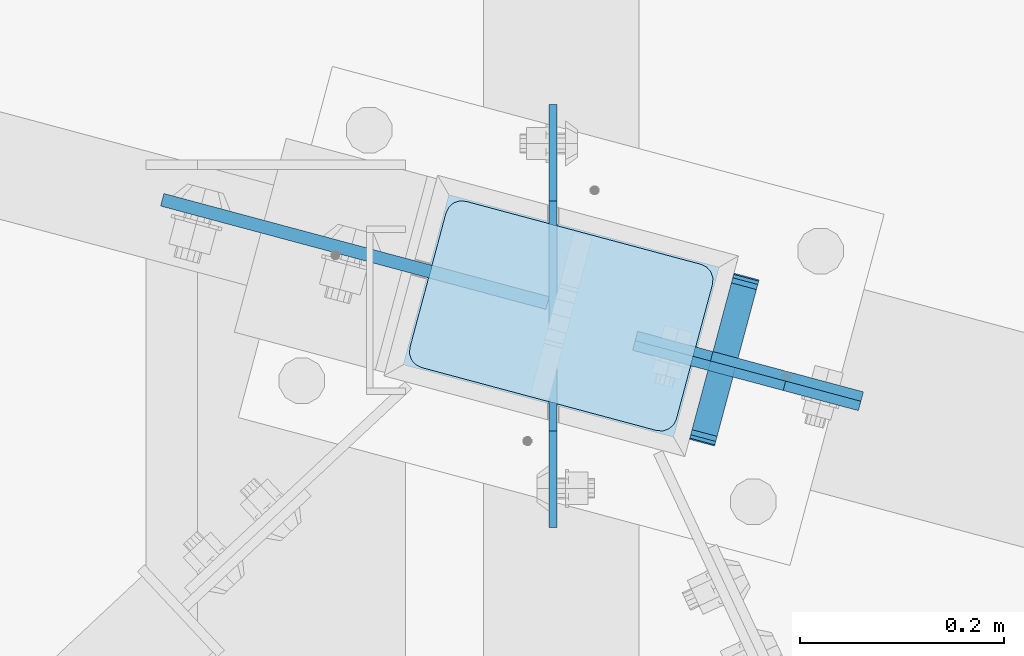
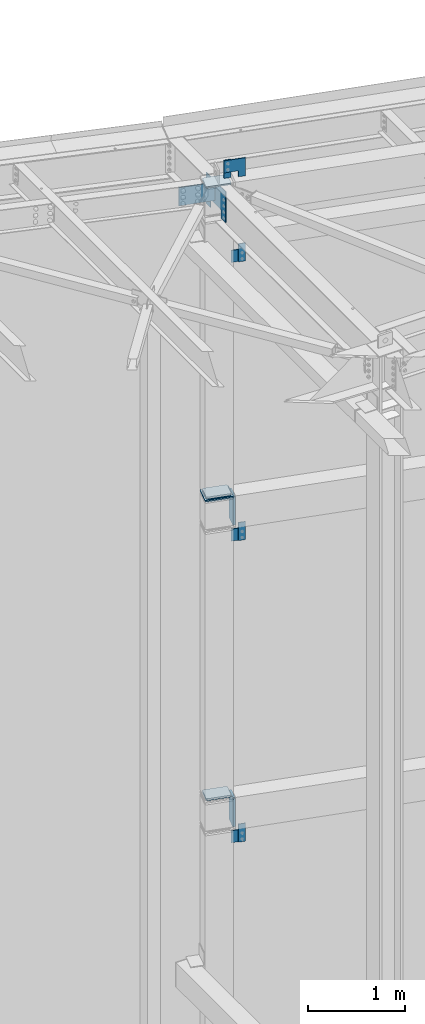
# One storey, part 1664 of 1763: 17 plates, 5 elements without a shape of their own.
"""IFC2X3 building model written with IfcOpenShell, lengths in millimetres."""

from ifc_helpers import new_model, si_unit, frame, origin_with_axes, place, context, subcontext, project, spatial, faceted_brep, material, type_object, element, aggregate, save


model = new_model("IFC2X3")

# Units and contexts
model_context = context("Model", 3, precision=1e-05, world=origin_with_axes())
body_context = subcontext(model_context, "Body", "Model", "MODEL_VIEW")
ifc_project = project(units=[si_unit("LENGTHUNIT", "METRE", prefix="MILLI"), si_unit("AREAUNIT", "SQUARE_METRE"), si_unit("VOLUMEUNIT", "CUBIC_METRE"), si_unit("MASSUNIT", "GRAM", prefix="KILO"), si_unit("TIMEUNIT", "SECOND"), si_unit("PLANEANGLEUNIT", "RADIAN"), si_unit("SOLIDANGLEUNIT", "STERADIAN"), si_unit("THERMODYNAMICTEMPERATUREUNIT", "DEGREE_CELSIUS"), si_unit("LUMINOUSINTENSITYUNIT", "LUMEN")], contexts=[model_context])

# Site, building, storey
site_placement = place(None, origin_with_axes())
site = spatial("IfcSite", under=ifc_project, at=site_placement, CompositionType="ELEMENT")
building_placement = place(site_placement, origin_with_axes())
building = spatial("IfcBuilding", under=site, at=building_placement, Name="Undefined", CompositionType="ELEMENT")
storey_placement = place(building_placement, origin_with_axes())
storey = spatial("IfcBuildingStorey", under=building, at=storey_placement, Name="Undefined", CompositionType="ELEMENT", Elevation=0.0)

# Assembly, plate
assembly_1_placement = place(storey_placement, origin_with_axes())
assembly_1 = element("IfcElementAssembly", 1, at=assembly_1_placement, inside=storey, Name="BEAM", AssemblyPlace="NOTDEFINED", PredefinedType="RIGID_FRAME")
ifc_material_1 = material(Name="STEEL/A36")
plate_type_1 = type_object("IfcPlateType", PredefinedType="NOTDEFINED")
plate_1_placement = place(assembly_1_placement, frame((-39453.9346929631, 66613.0335251458, 4267.19999084485), z_axis=(0.0, 0.0, -1.0), x_axis=(0.965925826295336, -0.25881904507913, 0.0)))
plate_1 = element("IfcPlate", 2, at=plate_1_placement, type_object=plate_type_1, material=ifc_material_1, Name="PLATE", context=body_context, shape_type="Brep", body=[
    faceted_brep([(0.0, -4.76249999999982, 0.0), (-2.83762346953154e-10, -4.7624999996915, 228.600006103516), (-2.83762346953154e-10, 4.76250000028813, 228.600006103517), (0.0, 4.76249999999982, 0.0), (76.1999969480166, -4.76249999961874, 228.600006103516), (76.1999969480166, 4.76250000036089, 228.600006103517), (76.1999969482931, -4.76249999991705, 0.0), (76.1999969482931, 4.76250000006257, 1.81898940354586e-12)], [[[0, 1, 2, 3]], [[1, 4, 5, 2]], [[4, 6, 7, 5]], [[6, 0, 3, 7]], [[5, 7, 3, 2]], [[6, 4, 1, 0]]]),
])

assembly_2_placement = place(storey_placement, origin_with_axes())
assembly_2 = element("IfcElementAssembly", 3, at=assembly_2_placement, inside=storey, Name="COLUMN", AssemblyPlace="NOTDEFINED", PredefinedType="RIGID_FRAME")
plate_2_placement = place(assembly_2_placement, frame((-39598.6758127814, 66661.6778126115, 12445.9953409909), z_axis=(-3.1917423766572e-06, 8.53930963785388e-07, 0.999999999994542), x_axis=(0.96592582365611, -0.258819054907767, 3.30399998729133e-06)))
plate_2 = element("IfcPlate", 4, at=plate_2_placement, type_object=plate_type_1, material=ifc_material_1, Name="PLATE", context=body_context, shape_type="Brep", body=[
    faceted_brep([(0.0, -4.76249999999982, 0.0), (-2.83762346953154e-10, -4.7624999996915, 228.600006103516), (-2.83762346953154e-10, 4.76250000028813, 228.600006103517), (0.0, 4.76249999999982, 0.0), (76.1999969480166, -4.76249999961874, 228.600006103516), (76.1999969480166, 4.76250000036089, 228.600006103517), (76.1999969482931, -4.76249999991705, 0.0), (76.1999969482931, 4.76250000006257, 1.81898940354586e-12)], [[[0, 1, 2, 3]], [[1, 4, 5, 2]], [[4, 6, 7, 5]], [[6, 0, 3, 7]], [[5, 7, 3, 2]], [[6, 4, 1, 0]]]),
])

assembly_3_placement = place(storey_placement, origin_with_axes())
assembly_3 = element("IfcElementAssembly", 5, at=assembly_3_placement, inside=storey, Name="BEAM", AssemblyPlace="NOTDEFINED", PredefinedType="RIGID_FRAME")
plate_3_placement = place(assembly_3_placement, frame((-39453.9346929706, 66613.0335251479, 8077.19999084485), z_axis=(0.0, 0.0, -1.0), x_axis=(0.965925826295336, -0.25881904507913, 0.0)))
plate_3 = element("IfcPlate", 6, at=plate_3_placement, type_object=plate_type_1, material=ifc_material_1, Name="PLATE", context=body_context, shape_type="Brep", body=[
    faceted_brep([(0.0, -4.76249999999982, 0.0), (-2.83762346953154e-10, -4.7624999996915, 228.600006103516), (-2.83762346953154e-10, 4.76250000028813, 228.600006103517), (0.0, 4.76249999999982, 0.0), (76.1999969480166, -4.76249999961874, 228.600006103516), (76.1999969480166, 4.76250000036089, 228.600006103517), (76.1999969482931, -4.76249999991705, 0.0), (76.1999969482931, 4.76250000006257, 1.81898940354586e-12)], [[[0, 1, 2, 3]], [[1, 4, 5, 2]], [[4, 6, 7, 5]], [[6, 0, 3, 7]], [[5, 7, 3, 2]], [[6, 4, 1, 0]]]),
])

assembly_4_placement = place(storey_placement, origin_with_axes())
assembly_4 = element("IfcElementAssembly", 7, at=assembly_4_placement, inside=storey, Name="BEAM", AssemblyPlace="NOTDEFINED", PredefinedType="RIGID_FRAME")
plate_4_placement = place(assembly_4_placement, frame((-39453.9346899535, 66613.0335364077, 11598.2749908449), z_axis=(0.0, 0.0, -1.0), x_axis=(0.965925826295336, -0.25881904507913, 0.0)))
plate_4 = element("IfcPlate", 8, at=plate_4_placement, type_object=plate_type_1, material=ifc_material_1, Name="PLATE", context=body_context, shape_type="Brep", body=[
    faceted_brep([(0.0, -4.76249999999982, 0.0), (-2.83762346953154e-10, -4.7624999996915, 228.600006103516), (-2.83762346953154e-10, 4.76250000028813, 228.600006103517), (0.0, 4.76249999999982, 0.0), (76.1999969480166, -4.76249999961874, 228.600006103516), (76.1999969480166, 4.76250000036089, 228.600006103517), (76.1999969482931, -4.76249999991705, 0.0), (76.1999969482931, 4.76250000006257, 1.81898940354586e-12)], [[[0, 1, 2, 3]], [[1, 4, 5, 2]], [[4, 6, 7, 5]], [[6, 0, 3, 7]], [[5, 7, 3, 2]], [[6, 4, 1, 0]]]),
])
aggregate(assembly_4, [plate_4])

# Plate
plate_type_2 = type_object("IfcPlateType", PredefinedType="NOTDEFINED")
plate_5_placement = place(assembly_1_placement, frame((-39491.0419311829, 66719.9497266416, 4284.92161424868), z_axis=(-1.25579324012506e-05, -4.68677477038e-05, 0.999999998822856), x_axis=(-0.258819045024454, -0.965925825091317, -4.85210000061005e-05)))
plate_5 = element("IfcPlate", 9, at=plate_5_placement, type_object=plate_type_2, material=ifc_material_1, Name="PLATE", context=body_context, shape_type="Brep", body=[
    faceted_brep([(-0.000210669619264081, -12.6999999999534, 15.8747893276304), (-0.0047190601399052, -12.6999999998734, 355.599795431186), (-0.00471906022721669, 12.7000000000335, 355.599795431181), (-0.000210669699299615, 12.6999999999462, 15.874789327625), (1.2036328949398, -12.6999999998734, 361.674959615151), (1.20363289484521, 12.7000000000189, 361.674959615146), (4.64488630341657, -12.6999999998734, 366.825251770753), (4.64488630330743, 12.7000000000189, 366.825251770748), (9.79513279069943, -12.6999999998807, 370.266573526937), (9.79513279059029, 12.7000000000116, 370.266573526933), (15.870280938434, -12.6999999998952, 371.47500610361), (15.8702809383467, 12.7000000000044, 371.475006103608), (152.395291187866, -12.7000000001281, 371.475006103574), (152.395291187757, 12.6999999997643, 371.475006103572), (158.470342028959, -12.7000000001353, 370.266613832635), (158.47034202885, 12.699999999757, 370.266613832629), (163.620536872309, -12.7000000001644, 366.825400721296), (163.620536872222, 12.6999999997352, 366.825400721291), (167.061818314192, -12.7000000001644, 361.675251535087), (167.06181831409, 12.6999999997279, 361.675251535082), (168.270291186484, -12.7000000001644, 355.600216727018), (168.270291186389, 12.6999999997279, 355.600216727014), (168.274798528968, -12.7000000002445, 15.8752106238717), (168.274798528873, 12.6999999996478, 15.8752106238662), (167.066446559853, -12.7000000002445, 9.80004645495683), (167.066446559766, 12.6999999996551, 9.80004645495319), (163.625193148131, -12.7000000002372, 4.64975431598214), (163.625193148022, 12.6999999996478, 4.64975431597668), (158.474946666858, -12.7000000002372, 1.2084325724245), (158.474946666771, 12.6999999996624, 1.20843257241904), (152.399798530452, -12.7000000002226, 4.20186552219093e-10), (152.399798530358, 12.6999999996697, 4.14729584008455e-10), (15.8747893290638, -12.6999999999898, 4.72937244921923e-11), (15.8747893289692, 12.6999999999098, 4.36557456851006e-11), (9.79973849928501, -12.699999999968, 1.20839226628777), (9.79973849918315, 12.6999999999243, 1.20839226628414), (4.64954366190068, -12.699999999968, 4.6496053649953), (4.64954366179882, 12.6999999999316, 4.64960536499166), (1.20826221675816, -12.6999999999607, 9.79975453459156), (1.20826221665629, 12.6999999999462, 9.79975453458792)], [[[0, 1, 2, 3]], [[1, 4, 5, 2]], [[4, 6, 7, 5]], [[6, 8, 9, 7]], [[8, 10, 11, 9]], [[10, 12, 13, 11]], [[12, 14, 15, 13]], [[14, 16, 17, 15]], [[16, 18, 19, 17]], [[18, 20, 21, 19]], [[20, 22, 23, 21]], [[22, 24, 25, 23]], [[24, 26, 27, 25]], [[26, 28, 29, 27]], [[28, 30, 31, 29]], [[30, 32, 33, 31]], [[32, 34, 35, 33]], [[34, 36, 37, 35]], [[36, 38, 39, 37]], [[38, 0, 3, 39]], [[5, 7, 9, 11, 13, 15, 17, 19, 21, 23, 25, 27, 29, 31, 33, 35, 37, 39, 3, 2]], [[38, 36, 34, 32, 30, 28, 26, 24, 22, 20, 18, 16, 14, 12, 10, 8, 6, 4, 1, 0]]]),
])

aggregate(assembly_1, [plate_5, plate_1])

plate_6_placement = place(assembly_3_placement, frame((-39491.0419311902, 66719.9497266432, 8094.92161424868), z_axis=(-1.25579324012506e-05, -4.68677477038e-05, 0.999999998822856), x_axis=(-0.258819045024454, -0.965925825091317, -4.85210000061005e-05)))
plate_6 = element("IfcPlate", 10, at=plate_6_placement, type_object=plate_type_2, material=ifc_material_1, Name="PLATE", context=body_context, shape_type="Brep", body=[
    faceted_brep([(-0.000210669619264081, -12.6999999999534, 15.8747893276304), (-0.0047190601399052, -12.6999999998734, 355.599795431186), (-0.00471906022721669, 12.7000000000335, 355.599795431181), (-0.000210669699299615, 12.6999999999462, 15.874789327625), (1.2036328949398, -12.6999999998734, 361.674959615151), (1.20363289484521, 12.7000000000189, 361.674959615146), (4.64488630341657, -12.6999999998734, 366.825251770753), (4.64488630330743, 12.7000000000189, 366.825251770748), (9.79513279069943, -12.6999999998807, 370.266573526937), (9.79513279059029, 12.7000000000116, 370.266573526933), (15.870280938434, -12.6999999998952, 371.47500610361), (15.8702809383467, 12.7000000000044, 371.475006103608), (152.395291187866, -12.7000000001281, 371.475006103574), (152.395291187757, 12.6999999997643, 371.475006103572), (158.470342028959, -12.7000000001353, 370.266613832635), (158.47034202885, 12.699999999757, 370.266613832629), (163.620536872309, -12.7000000001644, 366.825400721296), (163.620536872222, 12.6999999997352, 366.825400721291), (167.061818314192, -12.7000000001644, 361.675251535087), (167.06181831409, 12.6999999997279, 361.675251535082), (168.270291186484, -12.7000000001644, 355.600216727018), (168.270291186389, 12.6999999997279, 355.600216727014), (168.274798528968, -12.7000000002445, 15.8752106238717), (168.274798528873, 12.6999999996478, 15.8752106238662), (167.066446559853, -12.7000000002445, 9.80004645495683), (167.066446559766, 12.6999999996551, 9.80004645495319), (163.625193148131, -12.7000000002372, 4.64975431598214), (163.625193148022, 12.6999999996478, 4.64975431597668), (158.474946666858, -12.7000000002372, 1.2084325724245), (158.474946666771, 12.6999999996624, 1.20843257241904), (152.399798530452, -12.7000000002226, 4.20186552219093e-10), (152.399798530358, 12.6999999996697, 4.14729584008455e-10), (15.8747893290638, -12.6999999999898, 4.72937244921923e-11), (15.8747893289692, 12.6999999999098, 4.36557456851006e-11), (9.79973849928501, -12.699999999968, 1.20839226628777), (9.79973849918315, 12.6999999999243, 1.20839226628414), (4.64954366190068, -12.699999999968, 4.6496053649953), (4.64954366179882, 12.6999999999316, 4.64960536499166), (1.20826221675816, -12.6999999999607, 9.79975453459156), (1.20826221665629, 12.6999999999462, 9.79975453458792)], [[[0, 1, 2, 3]], [[1, 4, 5, 2]], [[4, 6, 7, 5]], [[6, 8, 9, 7]], [[8, 10, 11, 9]], [[10, 12, 13, 11]], [[12, 14, 15, 13]], [[14, 16, 17, 15]], [[16, 18, 19, 17]], [[18, 20, 21, 19]], [[20, 22, 23, 21]], [[22, 24, 25, 23]], [[24, 26, 27, 25]], [[26, 28, 29, 27]], [[28, 30, 31, 29]], [[30, 32, 33, 31]], [[32, 34, 35, 33]], [[34, 36, 37, 35]], [[36, 38, 39, 37]], [[38, 0, 3, 39]], [[5, 7, 9, 11, 13, 15, 17, 19, 21, 23, 25, 27, 29, 31, 33, 35, 37, 39, 3, 2]], [[38, 36, 34, 32, 30, 28, 26, 24, 22, 20, 18, 16, 14, 12, 10, 8, 6, 4, 1, 0]]]),
])

aggregate(assembly_3, [plate_6, plate_3])

plate_7_placement = place(assembly_2_placement, frame((-39780.8472022481, 66797.6028150253, 4686.3), z_axis=(0.965913267114843, -0.258865912030785, 0.0), x_axis=(-0.258865912030778, -0.965913267114844, 3.00823476209188e-08)))
plate_7 = element("IfcPlate", 11, at=plate_7_placement, type_object=plate_type_2, material=ifc_material_1, Name="PLATE", context=body_context, shape_type="Brep", body=[
    faceted_brep([(-2.18278728425503e-11, -12.7000000000007, 15.875), (-1.67347025126219e-10, -12.7000000000007, 253.999999999985), (-1.67347025126219e-10, 12.7000000000007, 253.999999999985), (-2.18278728425503e-11, 12.7000000000007, 15.875), (1.20841242121242, -12.7000000000007, 260.075099488779), (1.20841242121242, 12.7000000000007, 260.075099488779), (4.649679848495, -12.7000000000007, 265.225320151323), (4.649679848495, 12.7000000000007, 265.225320151323), (9.79990051103232, -12.7000000000007, 268.666587578606), (9.79990051103232, 12.7000000000007, 268.666587578606), (15.8749999998181, -12.7000000000007, 269.874999999993), (15.8749999998181, 12.7000000000007, 269.874999999993), (152.400009155084, -12.7000000000007, 269.875000000073), (152.400009155084, 12.7000000000007, 269.875000000073), (158.475108643877, -12.7000000000007, 268.6665875787), (158.475108643877, 12.7000000000007, 268.6665875787), (163.625329306422, -12.7000000000007, 265.225320151425), (163.625329306422, 12.7000000000007, 265.225320151425), (167.066596733705, -12.7000000000007, 260.07509948888), (167.066596733705, 12.7000000000007, 260.07509948888), (168.275009155092, -12.7000000000007, 254.000000000087), (168.275009155092, 12.7000000000007, 254.000000000087), (168.275009155237, -12.7000000000007, 15.8750000001019), (168.275009155237, 12.7000000000007, 15.8750000001019), (167.066596733865, -12.7000000000007, 9.79990051130881), (167.066596733865, 12.7000000000007, 9.79990051130881), (163.625329306582, -12.7000000000007, 4.64967984876421), (163.625329306582, 12.7000000000007, 4.64967984876421), (158.475108644045, -12.7000000000007, 1.20841242148163), (158.475108644045, 12.7000000000007, 1.20841242148163), (152.400000000001, -12.6999998092651, 0.0), (152.400000000001, 12.6999998092651, 0.0), (15.8749999999854, -12.7000000000007, 0.0), (15.8749999999854, 12.7000000000007, 0.0), (9.79990051119239, -12.7000000000007, 1.20841242137976), (9.79990051119239, 12.7000000000007, 1.20841242137976), (4.64967984864779, -12.7000000000007, 4.64967984866234), (4.64967984864779, 12.7000000000007, 4.64967984866234), (1.20841242136521, -12.7000000000007, 9.79990051119967), (1.20841242136521, 12.7000000000007, 9.79990051119967)], [[[0, 1, 2, 3]], [[1, 4, 5, 2]], [[4, 6, 7, 5]], [[6, 8, 9, 7]], [[8, 10, 11, 9]], [[10, 12, 13, 11]], [[12, 14, 15, 13]], [[14, 16, 17, 15]], [[16, 18, 19, 17]], [[18, 20, 21, 19]], [[20, 22, 23, 21]], [[22, 24, 25, 23]], [[24, 26, 27, 25]], [[26, 28, 29, 27]], [[28, 30, 31, 29]], [[30, 32, 33, 31]], [[32, 34, 35, 33]], [[34, 36, 37, 35]], [[36, 38, 39, 37]], [[38, 0, 3, 39]], [[5, 7, 9, 11, 13, 15, 17, 19, 21, 23, 25, 27, 29, 31, 33, 35, 37, 39, 3, 2]], [[38, 36, 34, 32, 30, 28, 26, 24, 22, 20, 18, 16, 14, 12, 10, 8, 6, 4, 1, 0]]]),
])

plate_8_placement = place(assembly_2_placement, frame((-39780.8472021543, 66797.6028150001, 8496.3), z_axis=(0.965913267114843, -0.258865912030785, 0.0), x_axis=(-0.258865912030778, -0.965913267114844, 3.00823476209188e-08)))
plate_8 = element("IfcPlate", 12, at=plate_8_placement, type_object=plate_type_2, material=ifc_material_1, Name="PLATE", context=body_context, shape_type="Brep", body=[
    faceted_brep([(-2.18278728425503e-11, -12.7000000000007, 15.875), (-1.67347025126219e-10, -12.7000000000007, 253.999999999985), (-1.67347025126219e-10, 12.7000000000007, 253.999999999985), (-2.18278728425503e-11, 12.7000000000007, 15.875), (1.20841242121242, -12.7000000000007, 260.075099488779), (1.20841242121242, 12.7000000000007, 260.075099488779), (4.649679848495, -12.7000000000007, 265.225320151323), (4.649679848495, 12.7000000000007, 265.225320151323), (9.79990051103232, -12.7000000000007, 268.666587578606), (9.79990051103232, 12.7000000000007, 268.666587578606), (15.8749999998181, -12.7000000000007, 269.874999999993), (15.8749999998181, 12.7000000000007, 269.874999999993), (152.400009155084, -12.7000000000007, 269.875000000073), (152.400009155084, 12.7000000000007, 269.875000000073), (158.475108643877, -12.7000000000007, 268.6665875787), (158.475108643877, 12.7000000000007, 268.6665875787), (163.625329306422, -12.7000000000007, 265.225320151425), (163.625329306422, 12.7000000000007, 265.225320151425), (167.066596733705, -12.7000000000007, 260.07509948888), (167.066596733705, 12.7000000000007, 260.07509948888), (168.275009155092, -12.7000000000007, 254.000000000087), (168.275009155092, 12.7000000000007, 254.000000000087), (168.275009155237, -12.7000000000007, 15.8750000001019), (168.275009155237, 12.7000000000007, 15.8750000001019), (167.066596733865, -12.7000000000007, 9.79990051130881), (167.066596733865, 12.7000000000007, 9.79990051130881), (163.625329306582, -12.7000000000007, 4.64967984876421), (163.625329306582, 12.7000000000007, 4.64967984876421), (158.475108644045, -12.7000000000007, 1.20841242148163), (158.475108644045, 12.7000000000007, 1.20841242148163), (152.400000000001, -12.6999998092651, 0.0), (152.400000000001, 12.6999998092651, 0.0), (15.8749999999854, -12.7000000000007, 0.0), (15.8749999999854, 12.7000000000007, 0.0), (9.79990051119239, -12.7000000000007, 1.20841242137976), (9.79990051119239, 12.7000000000007, 1.20841242137976), (4.64967984864779, -12.7000000000007, 4.64967984866234), (4.64967984864779, 12.7000000000007, 4.64967984866234), (1.20841242136521, -12.7000000000007, 9.79990051119967), (1.20841242136521, 12.7000000000007, 9.79990051119967)], [[[0, 1, 2, 3]], [[1, 4, 5, 2]], [[4, 6, 7, 5]], [[6, 8, 9, 7]], [[8, 10, 11, 9]], [[10, 12, 13, 11]], [[12, 14, 15, 13]], [[14, 16, 17, 15]], [[16, 18, 19, 17]], [[18, 20, 21, 19]], [[20, 22, 23, 21]], [[22, 24, 25, 23]], [[24, 26, 27, 25]], [[26, 28, 29, 27]], [[28, 30, 31, 29]], [[30, 32, 33, 31]], [[32, 34, 35, 33]], [[34, 36, 37, 35]], [[36, 38, 39, 37]], [[38, 0, 3, 39]], [[5, 7, 9, 11, 13, 15, 17, 19, 21, 23, 25, 27, 29, 31, 33, 35, 37, 39, 3, 2]], [[38, 36, 34, 32, 30, 28, 26, 24, 22, 20, 18, 16, 14, 12, 10, 8, 6, 4, 1, 0]]]),
])

plate_9_placement = place(assembly_2_placement, frame((-39780.8472021916, 66797.6028150101, 8455.025), z_axis=(0.965913267114843, -0.258865912030785, 0.0), x_axis=(-0.258865912030778, -0.965913267114844, 3.00823476209188e-08)))
plate_9 = element("IfcPlate", 13, at=plate_9_placement, type_object=plate_type_2, material=ifc_material_1, Name="PLATE", context=body_context, shape_type="Brep", body=[
    faceted_brep([(-2.18278728425503e-11, -12.7000000000007, 15.875), (-1.67347025126219e-10, -12.7000000000007, 253.999999999985), (-1.67347025126219e-10, 12.7000000000007, 253.999999999985), (-2.18278728425503e-11, 12.7000000000007, 15.875), (1.20841242121242, -12.7000000000007, 260.075099488779), (1.20841242121242, 12.7000000000007, 260.075099488779), (4.649679848495, -12.7000000000007, 265.225320151323), (4.649679848495, 12.7000000000007, 265.225320151323), (9.79990051103232, -12.7000000000007, 268.666587578606), (9.79990051103232, 12.7000000000007, 268.666587578606), (15.8749999998181, -12.7000000000007, 269.874999999993), (15.8749999998181, 12.7000000000007, 269.874999999993), (152.400009155084, -12.7000000000007, 269.875000000073), (152.400009155084, 12.7000000000007, 269.875000000073), (158.475108643877, -12.7000000000007, 268.6665875787), (158.475108643877, 12.7000000000007, 268.6665875787), (163.625329306422, -12.7000000000007, 265.225320151425), (163.625329306422, 12.7000000000007, 265.225320151425), (167.066596733705, -12.7000000000007, 260.07509948888), (167.066596733705, 12.7000000000007, 260.07509948888), (168.275009155092, -12.7000000000007, 254.000000000087), (168.275009155092, 12.7000000000007, 254.000000000087), (168.275009155237, -12.7000000000007, 15.8750000001019), (168.275009155237, 12.7000000000007, 15.8750000001019), (167.066596733865, -12.7000000000007, 9.79990051130881), (167.066596733865, 12.7000000000007, 9.79990051130881), (163.625329306582, -12.7000000000007, 4.64967984876421), (163.625329306582, 12.7000000000007, 4.64967984876421), (158.475108644045, -12.7000000000007, 1.20841242148163), (158.475108644045, 12.7000000000007, 1.20841242148163), (152.400000000001, -12.6999998092651, 0.0), (152.400000000001, 12.6999998092651, 0.0), (15.8749999999854, -12.7000000000007, 0.0), (15.8749999999854, 12.7000000000007, 0.0), (9.79990051119239, -12.7000000000007, 1.20841242137976), (9.79990051119239, 12.7000000000007, 1.20841242137976), (4.64967984864779, -12.7000000000007, 4.64967984866234), (4.64967984864779, 12.7000000000007, 4.64967984866234), (1.20841242136521, -12.7000000000007, 9.79990051119967), (1.20841242136521, 12.7000000000007, 9.79990051119967)], [[[0, 1, 2, 3]], [[1, 4, 5, 2]], [[4, 6, 7, 5]], [[6, 8, 9, 7]], [[8, 10, 11, 9]], [[10, 12, 13, 11]], [[12, 14, 15, 13]], [[14, 16, 17, 15]], [[16, 18, 19, 17]], [[18, 20, 21, 19]], [[20, 22, 23, 21]], [[22, 24, 25, 23]], [[24, 26, 27, 25]], [[26, 28, 29, 27]], [[28, 30, 31, 29]], [[30, 32, 33, 31]], [[32, 34, 35, 33]], [[34, 36, 37, 35]], [[36, 38, 39, 37]], [[38, 0, 3, 39]], [[5, 7, 9, 11, 13, 15, 17, 19, 21, 23, 25, 27, 29, 31, 33, 35, 37, 39, 3, 2]], [[38, 36, 34, 32, 30, 28, 26, 24, 22, 20, 18, 16, 14, 12, 10, 8, 6, 4, 1, 0]]]),
])

# Assembly, plate
assembly_5_placement = place(storey_placement, origin_with_axes())
assembly_5 = element("IfcElementAssembly", 14, at=assembly_5_placement, inside=storey, Name="BEAM", AssemblyPlace="NOTDEFINED", PredefinedType="RIGID_FRAME")
plate_type_3 = type_object("IfcPlateType", PredefinedType="NOTDEFINED")
plate_10_placement = place(assembly_5_placement, frame((-39380.3240270479, 66593.3096185596, 12674.5518666303), z_axis=(-9.02279432266368e-05, 2.41809847939294e-05, -0.999999995637099), x_axis=(-0.965925818045195, 0.258819059012118, 9.34120000055757e-05)))
plate_10 = element("IfcPlate", 15, at=plate_10_placement, type_object=plate_type_3, material=ifc_material_1, Name="PLATE", context=body_context, shape_type="Brep", body=[
    faceted_brep([(0.0, -4.76249999999982, 0.0), (-0.0147415312894736, -4.76250000055734, 228.577880859459), (-0.0147415312967496, 4.76249999946594, 228.577880859457), (0.0, 4.76249999999982, 0.0), (76.1926269535688, -4.76250000031723, 228.563140869262), (76.1926269535616, 4.76249999970605, 228.563140869261), (76.1999969485987, -4.76250000013533, 152.385253906345), (76.1999969485914, 4.76249999988795, 152.385253906343), (228.59263610909, -4.76249999964057, 152.399993896655), (228.592636109082, 4.76250000037544, 152.399993896655), (228.607376099128, -4.76249999928405, 2.14640749618411e-10), (228.607376099135, 4.76250000073924, 2.12821760214865e-10)], [[[0, 1, 2, 3]], [[1, 4, 5, 2]], [[4, 6, 7, 5]], [[6, 8, 9, 7]], [[8, 10, 11, 9]], [[10, 0, 3, 11]], [[5, 7, 9, 11, 3, 2]], [[10, 8, 6, 4, 1, 0]]]),
])
aggregate(assembly_5, [plate_10])

# Plate
plate_type_4 = type_object("IfcPlateType", PredefinedType="NOTDEFINED")
plate_11_placement = place(assembly_2_placement, frame((-39780.8472031505, 66797.6028121075, 12420.6), z_axis=(0.965913267114843, -0.258865912030785, 0.0), x_axis=(-0.258865912030778, -0.965913267114844, 3.00823476209188e-08)))
plate_11 = element("IfcPlate", 16, at=plate_11_placement, type_object=plate_type_4, material=ifc_material_1, Name="PLATE", context=body_context, shape_type="Brep", body=[
    faceted_brep([(7.27595761418343e-11, -9.52499999999964, 15.8750000001601), (1.13504938781261e-09, -9.52499999999964, 254.000000000065), (1.13504938781261e-09, 9.52499999999964, 254.000000000065), (7.27595761418343e-11, 9.52499999999964, 15.8750000001601), (1.20841242253664, -9.52499999999964, 260.075099488837), (1.20841242253664, 9.52499999999964, 260.075099488837), (4.64967984981922, -9.52499999999964, 265.225320151352), (4.64967984981922, 9.52499999999964, 265.225320151352), (9.79990051234927, -9.52499999999964, 268.666587578613), (9.79990051234927, 9.52499999999964, 268.666587578613), (15.8750000011278, -9.52499999999964, 269.874999999993), (15.8750000011278, 9.52499999999964, 269.874999999993), (152.400009155099, -9.52499999999964, 269.87500000008), (152.400009155099, 9.52499999999964, 269.87500000008), (158.475108643885, -9.52499999999964, 268.6665875787), (158.475108643885, 9.52499999999964, 268.6665875787), (163.625329306429, -9.52499999999964, 265.225320151425), (163.625329306429, 9.52499999999964, 265.225320151425), (167.066596733726, -9.52499999999964, 260.07509948888), (167.066596733726, 9.52499999999964, 260.07509948888), (168.275009155106, -9.52499999999964, 254.000000000087), (168.275009155106, 9.52499999999964, 254.000000000087), (168.275009155259, -9.52499999999964, 15.8750000008658), (168.275009155259, 9.52499999999964, 15.8750000008658), (167.066596733886, -9.52499999999964, 9.79990051209461), (167.066596733886, 9.52499999999964, 9.79990051209461), (163.625329306633, -9.52499999999964, 4.64967984955729), (163.625329306633, 9.52499999999964, 4.64967984955729), (158.475108644117, -9.52499999999964, 1.20841242226743), (158.475108644117, 9.52499999999964, 1.20841242226743), (152.400009155353, -9.52499999999964, 8.58562998473644e-10), (152.400009155353, 9.52499999999964, 8.58562998473644e-10), (15.8750000001673, -9.52499999999964, 8.73114913702011e-11), (15.8750000001673, 9.52499999999964, 8.73114913702011e-11), (9.79990051132336, -9.52499999999964, 1.20841242144525), (9.79990051132336, 9.52499999999964, 1.20841242144525), (4.64967984874238, -9.52499999999964, 4.64967984874238), (4.64967984874238, 9.52499999999964, 4.64967984874238), (1.20841242144525, -9.52499999999964, 9.79990051132336), (1.20841242144525, 9.52499999999964, 9.79990051132336)], [[[0, 1, 2, 3]], [[1, 4, 5, 2]], [[4, 6, 7, 5]], [[6, 8, 9, 7]], [[8, 10, 11, 9]], [[10, 12, 13, 11]], [[12, 14, 15, 13]], [[14, 16, 17, 15]], [[16, 18, 19, 17]], [[18, 20, 21, 19]], [[20, 22, 23, 21]], [[22, 24, 25, 23]], [[24, 26, 27, 25]], [[26, 28, 29, 27]], [[28, 30, 31, 29]], [[30, 32, 33, 31]], [[32, 34, 35, 33]], [[34, 36, 37, 35]], [[36, 38, 39, 37]], [[38, 0, 3, 39]], [[5, 7, 9, 11, 13, 15, 17, 19, 21, 23, 25, 27, 29, 31, 33, 35, 37, 39, 3, 2]], [[38, 36, 34, 32, 30, 28, 26, 24, 22, 20, 18, 16, 14, 12, 10, 8, 6, 4, 1, 0]]]),
])

ifc_material_2 = material(Name="STEEL/A572-50")
plate_type_5 = type_object("IfcPlateType", PredefinedType="NOTDEFINED")
plate_12_placement = place(assembly_2_placement, frame((-39793.1844873819, 66818.987968072, 8475.6625), z_axis=(0.965913267114843, -0.258865912030785, 0.0), x_axis=(-0.258865912030778, -0.965913267114844, 3.00823476209188e-08)))
plate_12 = element("IfcPlate", 17, at=plate_12_placement, type_object=plate_type_5, material=ifc_material_2, Name="PLATE", context=body_context, shape_type="Brep", body=[
    faceted_brep([(-7.27595761418343e-12, -7.9375, 0.0), (-1.96450855582952e-10, -7.9375, 304.799987792954), (-1.96450855582952e-10, 7.9375, 304.799987792954), (-7.27595761418343e-12, 7.9375, 0.0), (203.199996948031, -7.9375, 304.799987793078), (203.199996948031, 7.9375, 304.799987793078), (203.199996948228, -7.9375, 1.30967237055302e-10), (203.199996948228, 7.9375, 1.30967237055302e-10)], [[[0, 1, 2, 3]], [[1, 4, 5, 2]], [[4, 6, 7, 5]], [[6, 0, 3, 7]], [[5, 7, 3, 2]], [[6, 4, 1, 0]]]),
])

plate_type_6 = type_object("IfcPlateType", PredefinedType="NOTDEFINED")
plate_13_placement = place(assembly_2_placement, frame((-39377.8658925294, 66602.5119729023, 4038.59998474133), z_axis=(0.0, 0.0, 1.0), x_axis=(-0.965925827679309, 0.258819039914073, 0.0)))
plate_13 = element("IfcPlate", 18, at=plate_13_placement, type_object=plate_type_6, material=ifc_material_1, Name="PLATE", context=body_context, shape_type="Brep", body=[
    faceted_brep([(0.0, -4.76249999999982, 0.0), (-3.05175672110636e-06, -4.7625000002663, 152.399993896484), (-3.05175490211695e-06, 4.76249999972788, 152.399993896484), (0.0, 4.76249999999982, 0.0), (152.400009155272, -4.76249999975698, 152.399993896484), (152.400009155273, 4.76250000024447, 152.399993896484), (152.400009155272, -4.76249999948777, 5.45696821063757e-12), (152.400009155273, 4.76250000051368, 3.63797880709171e-12)], [[[0, 1, 2, 3]], [[1, 4, 5, 2]], [[4, 6, 7, 5]], [[6, 0, 3, 7]], [[5, 7, 3, 2]], [[6, 4, 1, 0]]]),
])

plate_14_placement = place(assembly_2_placement, frame((-39377.8658925294, 66602.5119729022, 7848.59998474133), z_axis=(0.0, 0.0, 1.0), x_axis=(-0.965925827679309, 0.258819039914073, 0.0)))
plate_14 = element("IfcPlate", 19, at=plate_14_placement, type_object=plate_type_6, material=ifc_material_1, Name="PLATE", context=body_context, shape_type="Brep", body=[
    faceted_brep([(0.0, -4.76249999999982, 0.0), (-3.05175672110636e-06, -4.7625000002663, 152.399993896484), (-3.05175490211695e-06, 4.76249999972788, 152.399993896484), (0.0, 4.76249999999982, 0.0), (152.400009155272, -4.76249999975698, 152.399993896484), (152.400009155273, 4.76250000024447, 152.399993896484), (152.400009155272, -4.76249999948777, 5.45696821063757e-12), (152.400009155273, 4.76250000051368, 3.63797880709171e-12)], [[[0, 1, 2, 3]], [[1, 4, 5, 2]], [[4, 6, 7, 5]], [[6, 0, 3, 7]], [[5, 7, 3, 2]], [[6, 4, 1, 0]]]),
])

plate_15_placement = place(assembly_2_placement, frame((-39377.8658925295, 66602.5119729022, 11369.6749847413), z_axis=(0.0, 0.0, 1.0), x_axis=(-0.965925827679309, 0.258819039914073, 0.0)))
plate_15 = element("IfcPlate", 20, at=plate_15_placement, type_object=plate_type_6, material=ifc_material_1, Name="PLATE", context=body_context, shape_type="Brep", body=[
    faceted_brep([(0.0, -4.76249999999982, 0.0), (-3.05175672110636e-06, -4.7625000002663, 152.399993896484), (-3.05175490211695e-06, 4.76249999972788, 152.399993896484), (0.0, 4.76249999999982, 0.0), (152.400009155272, -4.76249999975698, 152.399993896484), (152.400009155273, 4.76250000024447, 152.399993896484), (152.400009155272, -4.76249999948777, 5.45696821063757e-12), (152.400009155273, 4.76250000051368, 3.63797880709171e-12)], [[[0, 1, 2, 3]], [[1, 4, 5, 2]], [[4, 6, 7, 5]], [[6, 0, 3, 7]], [[5, 7, 3, 2]], [[6, 4, 1, 0]]]),
])

plate_type_7 = type_object("IfcPlateType", PredefinedType="NOTDEFINED")
plate_16_placement = place(assembly_2_placement, frame((-39817.236788335, 66729.2803019243, 12411.1745289724), z_axis=(0.0, 0.0, -1.0), x_axis=(0.965925826295336, -0.25881904507913, 0.0)))
plate_16 = element("IfcPlate", 21, at=plate_16_placement, type_object=plate_type_7, material=ifc_material_2, Name="PLATE", context=body_context, shape_type="Brep", body=[
    faceted_brep([(0.0, -6.34999999999491, 1.45519152283669e-11), (-254.000122069607, -6.34999999922729, 6.31189323030412e-10), (-254.000122069629, 6.35000000085711, 6.31189323030412e-10), (0.0, 6.34999999999491, -2.91038304567337e-11), (-254.000122069607, -6.34999999922729, 230.1875), (-254.000122069629, 6.35000000085711, 230.1875), (136.128097533816, -6.35000000047876, 230.1875), (136.128097533794, 6.34999999960564, 230.1875), (136.128097533816, -6.35000000047876, -3.38332029059529e-10), (136.128097533794, 6.34999999960564, -3.38332029059529e-10)], [[[0, 1, 2, 3]], [[1, 4, 5, 2]], [[4, 6, 7, 5]], [[6, 8, 9, 7]], [[8, 0, 3, 9]], [[5, 7, 9, 3, 2]], [[8, 6, 4, 1, 0]]]),
])

plate_type_8 = type_object("IfcPlateType", PredefinedType="NOTDEFINED")
plate_17_placement = place(assembly_2_placement, frame((-39680.2266170545, 66787.6516242321, 12415.8375), z_axis=(0.0, 0.0, -1.0), x_axis=(0.0, -1.0, 0.0)))
plate_17 = element("IfcPlate", 22, at=plate_17_placement, type_object=plate_type_8, material=ifc_material_1, Name="PLATE", context=body_context, shape_type="Brep", body=[
    faceted_brep([(-6.24711784215469, -3.96899999999732, 0.0), (-6.24711785012914, 3.96899999999732, 0.0), (-6.24711785012914, 3.96899999999732, 4.76250000069376), (-6.24711784215469, -3.96899999999732, 4.76250000069376), (218.73669258265, -3.96899999999732, 4.76250000069376), (218.736692574676, 3.96899999999732, 4.76250000069376), (218.745232156347, 3.96899999999732, 0.0), (218.745232164321, -3.96899999999732, 0.0), (-100.53636932373, -3.96899999999732, 0.0), (-100.53636932373, -3.96899999999732, 388.9375), (-100.53636932373, 3.96899999999732, 388.9375), (-100.53636932373, 3.96899999999732, 0.0), (-2.44707844758523, -3.96899999999732, 388.9375), (-2.31119944482634, 3.96899999999732, 388.9375), (-2.44707844758523, -3.96899999999732, 285.750000053227), (-2.31119944482634, 3.96899999999732, 285.750000053227), (211.936404206775, -3.96899999999732, 285.750000053227), (212.072283209549, 3.96899999999732, 285.750000053227), (211.936404206819, -3.96899999999732, 388.937500053227), (212.072283209593, 3.96899999999732, 388.9375), (313.034484863281, -3.96899999999732, 388.9375), (313.034484863281, 3.96899999999732, 388.9375), (313.034484863281, -3.96899999999732, 0.0), (313.034484863281, 3.96899999999732, 0.0)], [[[0, 1, 2, 3]], [[4, 5, 6, 7]], [[3, 2, 5, 4]], [[8, 9, 10, 11]], [[10, 9, 12, 13]], [[12, 14, 15, 13]], [[16, 17, 15, 14]], [[18, 19, 17, 16]], [[20, 21, 19, 18]], [[20, 22, 23, 21]], [[23, 22, 7, 6]], [[1, 11, 10, 13, 15, 17, 19, 21, 23, 6, 5, 2]], [[8, 11, 1, 0]], [[22, 20, 18, 16, 14, 12, 9, 8, 0, 3, 4, 7]]]),
])

aggregate(assembly_2, [plate_2, plate_13, plate_14, plate_15, plate_11, plate_16, plate_17, plate_7, plate_8, plate_9, plate_12])

save(model, "model.ifc")
